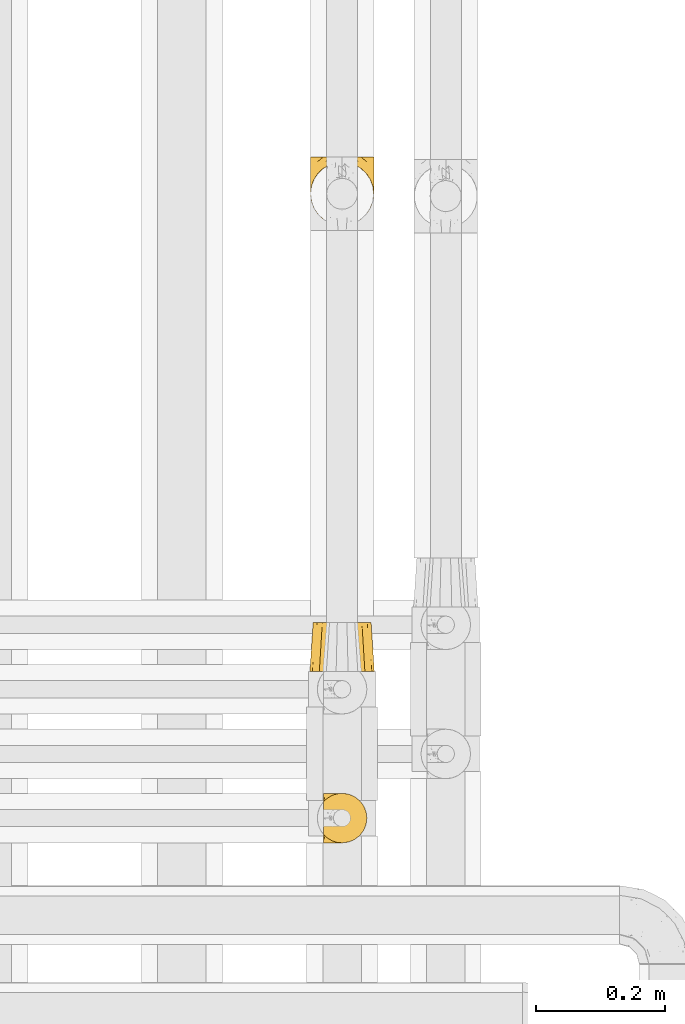
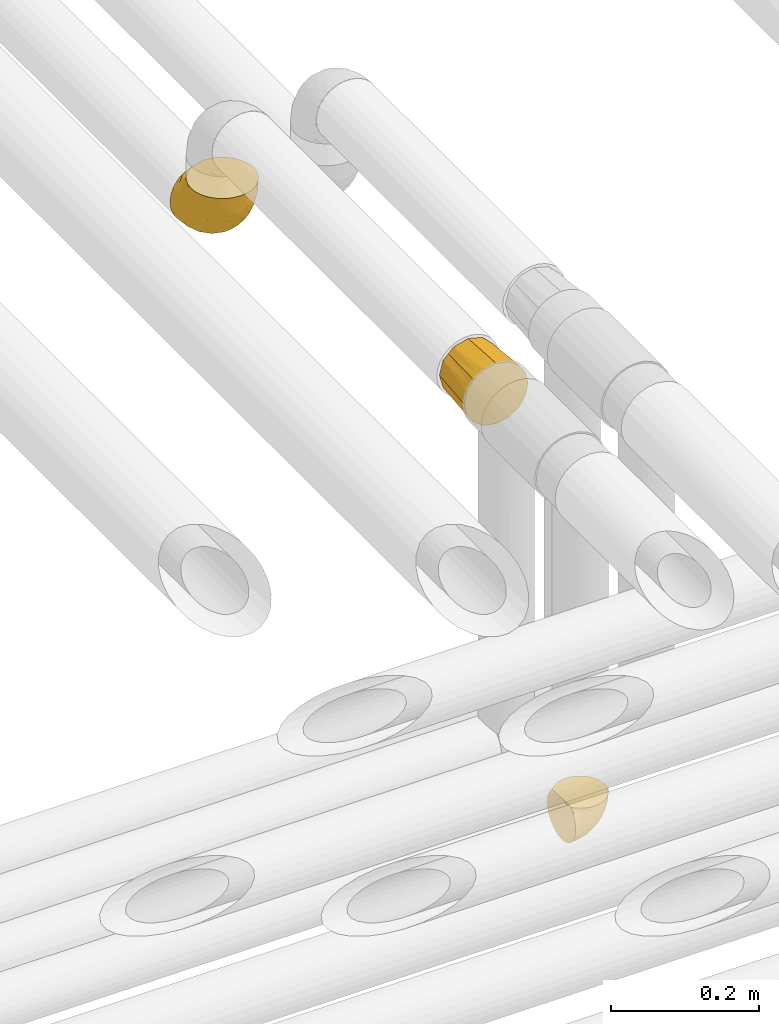
# One storey, part 344 of 827: 3 coverings.
"""IFC2X3 building model written with IfcOpenShell, lengths in millimetres."""

from ifc_helpers import new_model, entity, si_unit, converted_unit, derived_unit, direction, frame, origin, place, context, subcontext, project, spatial, faceted_brep, element, save


model = new_model("IFC2X3")

# Units and contexts
model_context = context("Model", 3, precision=0.01, world=origin(), true_north=direction((6.12303176911189e-17, 1.0)))
body_context = subcontext(model_context, "Body", "Model", "MODEL_VIEW")
ifc_project = project(units=[si_unit("LENGTHUNIT", "METRE", prefix="MILLI"), si_unit("AREAUNIT", "SQUARE_METRE"), si_unit("VOLUMEUNIT", "CUBIC_METRE"), converted_unit("PLANEANGLEUNIT", "DEGREE", entity("IfcRatioMeasure", 0.0174532925199433), si_unit("PLANEANGLEUNIT", "RADIAN"), dimensions=[0, 0, 0, 0, 0, 0, 0]), si_unit("MASSUNIT", "GRAM", prefix="KILO"), derived_unit("MASSDENSITYUNIT", [(si_unit("MASSUNIT", "GRAM", prefix="KILO"), 1), (si_unit("LENGTHUNIT", "METRE"), -3)]), derived_unit("MOMENTOFINERTIAUNIT", [(si_unit("LENGTHUNIT", "METRE"), 4)]), si_unit("TIMEUNIT", "SECOND"), si_unit("FREQUENCYUNIT", "HERTZ"), si_unit("THERMODYNAMICTEMPERATUREUNIT", "DEGREE_CELSIUS"), derived_unit("THERMALTRANSMITTANCEUNIT", [(si_unit("MASSUNIT", "GRAM", prefix="KILO"), 1), (si_unit("THERMODYNAMICTEMPERATUREUNIT", "KELVIN"), -1), (si_unit("TIMEUNIT", "SECOND"), -3)]), derived_unit("VOLUMETRICFLOWRATEUNIT", [(si_unit("LENGTHUNIT", "METRE"), 3), (si_unit("TIMEUNIT", "SECOND"), -1)]), derived_unit("MASSFLOWRATEUNIT", [(si_unit("MASSUNIT", "GRAM", prefix="KILO"), 1), (si_unit("TIMEUNIT", "SECOND"), -1)]), derived_unit("ROTATIONALFREQUENCYUNIT", [(si_unit("TIMEUNIT", "SECOND"), -1)]), si_unit("ELECTRICCURRENTUNIT", "AMPERE"), si_unit("ELECTRICVOLTAGEUNIT", "VOLT"), si_unit("POWERUNIT", "WATT"), si_unit("FORCEUNIT", "NEWTON", prefix="KILO"), si_unit("ILLUMINANCEUNIT", "LUX"), si_unit("LUMINOUSFLUXUNIT", "LUMEN"), si_unit("LUMINOUSINTENSITYUNIT", "CANDELA"), derived_unit("USERDEFINED", [(si_unit("MASSUNIT", "GRAM", prefix="KILO"), -1), (si_unit("LENGTHUNIT", "METRE"), -2), (si_unit("TIMEUNIT", "SECOND"), 3), (si_unit("LUMINOUSFLUXUNIT", "LUMEN"), 1)]), derived_unit("LINEARVELOCITYUNIT", [(si_unit("LENGTHUNIT", "METRE"), 1), (si_unit("TIMEUNIT", "SECOND"), -1)]), si_unit("PRESSUREUNIT", "PASCAL"), derived_unit("USERDEFINED", [(si_unit("LENGTHUNIT", "METRE"), -2), (si_unit("MASSUNIT", "GRAM", prefix="KILO"), 1), (si_unit("TIMEUNIT", "SECOND"), -2)]), derived_unit("LINEARFORCEUNIT", [(si_unit("MASSUNIT", "GRAM", prefix="KILO"), 1), (si_unit("LENGTHUNIT", "METRE"), 1), (si_unit("TIMEUNIT", "SECOND"), -2), (si_unit("LENGTHUNIT", "METRE"), -1)]), derived_unit("PLANARFORCEUNIT", [(si_unit("MASSUNIT", "GRAM", prefix="KILO"), 1), (si_unit("LENGTHUNIT", "METRE"), 1), (si_unit("TIMEUNIT", "SECOND"), -2), (si_unit("LENGTHUNIT", "METRE"), -2)])], contexts=[model_context])

# Site, building, storey
site_placement = place(None, origin())
site = spatial("IfcSite", under=ifc_project, at=site_placement, CompositionType="ELEMENT")
building_placement = place(site_placement, origin())
building = spatial("IfcBuilding", under=site, at=building_placement, CompositionType="ELEMENT")
storey_placement = place(building_placement, frame((0.0, 0.0, 28200.0)))
storey = spatial("IfcBuildingStorey", under=building, at=storey_placement, Name="08", CompositionType="ELEMENT", Elevation=28200.0)

# Coverings
covering_1_placement = place(storey_placement, frame((36438.02, 15249.95, 2959.95)))
element("IfcCovering", 1, at=covering_1_placement, inside=storey, Name=":ADSK_", ObjectType=":ADSK_", PredefinedType="INSULATION", context=body_context, shape_type="Brep", body=[
    faceted_brep([(1.6, 74.68, 23.36), (1.6, 70.1, 16.07), (1.6, 64.01, 9.98), (1.6, 56.72, 5.4), (1.6, 48.6, 2.56), (1.6, 40.05, 1.6), (1.6, 31.49, 2.56), (1.6, 23.36, 5.41), (1.6, 16.07, 9.99), (1.6, 9.98, 16.08), (1.6, 5.4, 23.37), (1.6, 2.56, 31.49), (1.6, 1.6, 40.05), (1.6, 2.46, 48.15), (1.6, 5.01, 55.88), (1.6, 9.13, 62.9), (1.6, 14.62, 68.89), (1.6, 16.82, 68.89), (1.6, 18.56, 68.89), (1.6, 20.52, 68.89), (1.6, 22.49, 68.89), (1.6, 24.46, 68.89), (1.6, 26.42, 68.89), (1.6, 28.39, 68.89), (1.6, 30.36, 68.89), (1.6, 32.55, 68.89), (1.6, 34.75, 68.89), (1.6, 36.94, 68.89), (1.6, 39.13, 68.89), (1.6, 41.33, 68.89), (1.6, 43.52, 68.89), (1.6, 45.72, 68.89), (1.6, 47.91, 68.89), (1.6, 50.11, 68.89), (1.6, 52.3, 68.89), (1.6, 54.49, 68.89), (1.6, 56.69, 68.89), (1.6, 58.88, 68.89), (1.6, 61.08, 68.89), (1.6, 63.27, 68.89), (1.6, 65.47, 68.89), (1.6, 70.97, 62.89), (1.6, 75.09, 55.86), (1.6, 77.64, 48.13), (1.6, 78.5, 40.05), (1.6, 77.53, 31.49), (1.85, 14.62, 69.15), (7.85, 9.12, 69.15), (14.87, 5.0, 69.15), (22.6, 2.46, 69.15), (30.7, 1.6, 69.15), (40.65, 2.91, 69.15), (49.92, 6.75, 69.15), (57.88, 12.86, 69.15), (63.99, 20.82, 69.15), (67.84, 30.09, 69.15), (69.15, 40.05, 69.15), (67.84, 50.0, 69.15), (63.99, 59.27, 69.15), (57.88, 67.23, 69.15), (49.92, 73.34, 69.15), (40.65, 77.19, 69.15), (30.7, 78.5, 69.15), (22.6, 77.63, 69.15), (14.87, 75.09, 69.15), (7.85, 70.97, 69.15), (1.85, 65.47, 69.15), (1.85, 63.27, 69.15), (1.85, 62.29, 69.15), (1.85, 60.7, 69.15), (1.85, 59.11, 69.15), (1.85, 57.52, 69.15), (1.85, 55.93, 69.15), (1.85, 54.34, 69.15), (1.85, 52.76, 69.15), (1.85, 51.17, 69.15), (1.85, 49.58, 69.15), (1.85, 47.99, 69.15), (1.85, 46.4, 69.15), (1.85, 44.81, 69.15), (1.85, 43.22, 69.15), (1.85, 41.63, 69.15), (1.85, 40.05, 69.15), (1.85, 38.46, 69.15), (1.85, 36.87, 69.15), (1.85, 35.28, 69.15), (1.85, 33.69, 69.15), (1.85, 32.1, 69.15), (1.85, 30.51, 69.15), (1.85, 28.92, 69.15), (1.85, 27.33, 69.15), (1.85, 25.37, 69.15), (1.85, 23.4, 69.15), (1.85, 21.21, 69.15), (1.85, 19.01, 69.15), (1.85, 16.82, 69.15), (1.77, 42.32, 68.96), (1.78, 44.02, 68.97), (1.77, 47.13, 68.97), (1.77, 48.74, 68.97), (1.76, 23.57, 68.95), (1.77, 25.13, 68.96), (1.79, 61.34, 68.98), (1.78, 22.02, 68.97), (1.78, 29.72, 68.97), (1.78, 56.73, 68.98), (1.78, 55.14, 68.97), (1.78, 37.66, 68.97), (1.74, 64.12, 68.94), (1.78, 28.13, 68.98), (1.78, 26.62, 68.98), (1.77, 31.46, 68.96), (1.78, 16.16, 68.97), (1.78, 39.16, 68.98), (1.78, 50.37, 68.98), (1.77, 17.69, 68.97), (1.77, 19.17, 68.96), (1.77, 62.78, 68.97), (1.78, 58.35, 68.97), (1.78, 45.53, 68.98), (1.77, 59.91, 68.96), (1.77, 65.47, 68.97), (1.72, 65.47, 68.94), (1.66, 65.47, 68.92), (1.77, 14.62, 68.97), (1.8, 14.62, 69.02), (1.82, 14.62, 69.08), (1.79, 20.59, 68.98), (1.78, 32.99, 68.97), (1.79, 34.48, 68.98), (1.78, 51.91, 68.97), (1.82, 65.47, 69.08), (1.8, 65.47, 69.02), (1.76, 53.48, 68.96), (1.66, 14.62, 68.92), (1.72, 14.62, 68.94), (1.78, 40.77, 68.97), (1.77, 35.97, 68.96), (9.41, 7.84, 67.02), (17.65, 3.53, 63.33), (7.41, 8.32, 64.61), (15.21, 2.19, 51.4), (7.41, 3.53, 53.1), (16.15, 1.6, 43.94), (28.75, 1.6, 61.87), (13.67, 4.57, 61.54), (12.79, 3.96, 57.95), (19.18, 2.28, 56.12), (29.16, 1.6, 63.4), (9.04, 7.69, 65.41), (5.74, 8.32, 63.04), (3.72, 7.84, 61.33), (8.87, 1.6, 41.99), (21.47, 1.6, 49.27), (26.8, 1.6, 54.6), (9.53, 4.34, 56.6), (7.34, 1.6, 41.58), (37.63, 29.63, 13.72), (17.92, 27.34, 5.82), (27.45, 40.05, 6.74), (37.01, 2.39, 58.82), (34.22, 2.43, 51.58), (45.87, 9.07, 42.09), (56.57, 16.64, 46.12), (52.31, 9.54, 55.56), (42.07, 4.52, 52.38), (44.74, 4.52, 61.54), (21.49, 7.49, 23.76), (11.02, 7.49, 20.5), (15.64, 12.85, 14.64), (26.02, 2.35, 41.77), (36.59, 22.66, 16.28), (65.49, 32.9, 49.4), (63.99, 25.33, 52.34), (15.2, 40.05, 4.3), (60.27, 16.64, 58.67), (45.25, 19.99, 25.26), (35.21, 16.37, 20.17), (22.52, 3.26, 34.7), (12.03, 3.75, 28.67), (13.32, 19.58, 8.62), (35.9, 7.5, 33.37), (33.87, 4.04, 41.35), (25.73, 13.94, 17.15), (26.34, 19.58, 12.68), (46.78, 28.21, 21.47), (59.54, 24.75, 41.11), (60.18, 31.42, 37.53), (53.93, 26.2, 30.64), (53.36, 33.36, 26.66), (49.36, 40.05, 21.38), (38.4, 40.05, 14.06), (66.44, 40.05, 55.54), (50.09, 16.14, 35.17), (41.08, 12.85, 29.04), (31.14, 10.47, 24.34), (28.19, 6.49, 29.33), (64.0, 40.05, 43.3), (56.68, 40.05, 32.34), (43.9, 75.57, 57.75), (65.46, 47.37, 49.41), (52.22, 52.91, 27.85), (37.61, 50.46, 13.7), (15.64, 67.23, 14.63), (13.31, 60.5, 8.61), (50.02, 70.55, 48.85), (59.28, 63.45, 54.13), (53.05, 62.61, 37.84), (21.48, 72.6, 23.75), (11.01, 72.6, 20.49), (12.03, 76.34, 28.66), (41.02, 59.34, 20.83), (35.39, 77.76, 55.15), (26.8, 78.5, 54.6), (28.75, 78.5, 61.87), (7.34, 78.5, 41.58), (65.81, 53.16, 57.58), (53.28, 70.55, 59.91), (59.8, 48.88, 36.94), (61.82, 54.76, 45.72), (17.91, 52.74, 5.82), (41.4, 71.93, 37.91), (40.48, 75.79, 50.18), (26.34, 60.5, 12.67), (31.68, 77.86, 49.29), (27.68, 77.64, 42.64), (16.15, 78.5, 43.94), (21.47, 78.5, 49.27), (28.05, 67.23, 19.45), (22.54, 76.82, 34.7), (8.87, 78.5, 41.99), (37.3, 77.8, 62.29), (41.07, 67.23, 29.01), (32.24, 73.2, 31.47), (47.4, 67.66, 37.18), (35.77, 75.99, 43.45), (17.65, 76.57, 63.33), (11.06, 73.21, 67.23), (8.55, 71.93, 66.07), (6.63, 71.07, 65.22), (12.77, 75.09, 61.99), (12.79, 76.13, 57.95), (7.41, 76.57, 53.09), (18.97, 77.69, 56.84), (3.72, 72.26, 61.33), (5.76, 71.77, 63.06), (15.21, 77.9, 51.41), (9.52, 75.75, 56.61)], [[[0, 1, 2, 3, 4, 5, 6, 7, 8, 9, 10, 11, 12, 13, 14, 15, 16, 17, 18, 19, 20, 21, 22, 23, 24, 25, 26, 27, 28, 29, 30, 31, 32, 33, 34, 35, 36, 37, 38, 39, 40, 41, 42, 43, 44, 45]], [[46, 47, 48, 49, 50, 51, 52, 53, 54, 55, 56, 57, 58, 59, 60, 61, 62, 63, 64, 65, 66, 67, 68, 69, 70, 71, 72, 73, 74, 75, 76, 77, 78, 79, 80, 81, 82, 83, 84, 85, 86, 87, 88, 89, 90, 91, 92, 93, 94, 95]], [[96, 97, 30]], [[98, 77, 99]], [[100, 101, 21]], [[69, 68, 102]], [[20, 19, 103]], [[24, 23, 104]], [[20, 103, 100]], [[72, 105, 106]], [[84, 83, 107]], [[89, 88, 104]], [[108, 67, 66]], [[109, 110, 90]], [[111, 25, 24]], [[112, 17, 16]], [[82, 113, 83]], [[109, 23, 22]], [[114, 76, 75]], [[105, 36, 106]], [[104, 111, 24]], [[18, 115, 116]], [[97, 96, 80]], [[67, 108, 117]], [[105, 71, 118]], [[31, 97, 119]], [[102, 120, 69]], [[108, 121, 122, 123, 40]], [[112, 95, 115]], [[17, 115, 18]], [[94, 116, 115]], [[117, 68, 67]], [[38, 117, 39]], [[112, 124, 125, 126, 46]], [[17, 112, 115]], [[70, 120, 118]], [[39, 117, 108]], [[120, 38, 37]], [[120, 37, 118]], [[120, 70, 69]], [[116, 94, 127]], [[128, 86, 129]], [[117, 38, 102]], [[74, 130, 75]], [[99, 33, 32]], [[115, 95, 94]], [[39, 108, 40]], [[108, 66, 131, 132, 121]], [[105, 72, 71]], [[118, 37, 36]], [[71, 70, 118]], [[35, 106, 36]], [[36, 105, 118]], [[35, 133, 106]], [[74, 73, 133]], [[106, 133, 73]], [[99, 114, 33]], [[133, 35, 34]], [[73, 72, 106]], [[95, 112, 46]], [[112, 16, 134, 135, 124]], [[130, 114, 75]], [[99, 76, 114]], [[114, 130, 33]], [[34, 33, 130]], [[78, 77, 98]], [[98, 119, 78]], [[130, 133, 34]], [[133, 130, 74]], [[79, 97, 80]], [[98, 99, 32]], [[98, 32, 31]], [[77, 76, 99]], [[97, 79, 119]], [[136, 96, 29]], [[30, 97, 31]], [[136, 29, 28]], [[81, 80, 96]], [[29, 96, 30]], [[31, 119, 98]], [[119, 79, 78]], [[96, 136, 81]], [[82, 81, 136]], [[113, 107, 83]], [[84, 107, 137]], [[107, 27, 137]], [[113, 28, 107]], [[27, 107, 28]], [[85, 84, 137]], [[137, 27, 26]], [[113, 136, 28]], [[136, 113, 82]], [[109, 89, 104]], [[86, 85, 129]], [[89, 109, 90]], [[111, 87, 128]], [[26, 129, 137]], [[88, 111, 104]], [[25, 111, 128]], [[22, 110, 109]], [[23, 109, 104]], [[110, 91, 90]], [[100, 92, 101]], [[110, 22, 101]], [[91, 110, 101]], [[116, 19, 18]], [[111, 88, 87]], [[127, 103, 19]], [[25, 128, 26]], [[86, 128, 87]], [[128, 129, 26]], [[137, 129, 85]], [[120, 102, 38]], [[117, 102, 68]], [[91, 101, 92]], [[21, 101, 22]], [[93, 92, 103]], [[100, 21, 20]], [[100, 103, 92]], [[127, 93, 103]], [[93, 127, 94]], [[116, 127, 19]], [[126, 138, 47]], [[48, 138, 139]], [[140, 125, 124]], [[141, 142, 143]], [[144, 49, 139]], [[145, 140, 146]], [[48, 139, 49]], [[139, 145, 147]], [[49, 144, 148, 50]], [[126, 125, 149]], [[14, 13, 142]], [[150, 146, 140]], [[149, 140, 145]], [[151, 150, 135]], [[151, 14, 142]], [[16, 15, 134]], [[13, 152, 142]], [[124, 150, 140]], [[141, 143, 153]], [[14, 151, 15]], [[15, 151, 134]], [[47, 46, 126]], [[139, 154, 144]], [[138, 48, 47]], [[125, 140, 149]], [[135, 134, 151]], [[146, 155, 141]], [[145, 146, 147]], [[149, 139, 138]], [[147, 153, 154]], [[147, 146, 141]], [[139, 147, 154]], [[139, 149, 145]], [[149, 138, 126]], [[147, 141, 153]], [[146, 150, 155]], [[151, 155, 150]], [[142, 141, 155]], [[13, 12, 156, 152]], [[152, 143, 142]], [[151, 142, 155]], [[150, 124, 135]], [[157, 158, 159]], [[160, 154, 161]], [[162, 163, 164]], [[165, 166, 160]], [[167, 168, 169]], [[153, 170, 161]], [[156, 12, 11]], [[158, 157, 171]], [[172, 55, 173]], [[158, 6, 174]], [[175, 54, 53]], [[52, 166, 164]], [[52, 164, 53]], [[54, 175, 173]], [[166, 52, 51]], [[176, 177, 171]], [[178, 143, 179]], [[156, 11, 179]], [[8, 7, 180]], [[169, 9, 8]], [[179, 143, 152, 156]], [[179, 11, 10]], [[168, 179, 10]], [[181, 162, 182]], [[179, 167, 178]], [[183, 184, 177]], [[183, 169, 184]], [[176, 171, 185]], [[172, 186, 187]], [[158, 7, 6]], [[159, 158, 174]], [[184, 180, 158]], [[54, 173, 55]], [[180, 169, 8]], [[188, 189, 187]], [[9, 168, 10]], [[186, 188, 187]], [[190, 157, 159, 191]], [[55, 172, 192]], [[176, 193, 194]], [[161, 170, 182]], [[162, 164, 165]], [[175, 164, 163]], [[51, 50, 148]], [[167, 195, 196]], [[178, 182, 170]], [[6, 5, 174]], [[158, 180, 7]], [[169, 180, 184]], [[169, 168, 9]], [[179, 168, 167]], [[182, 162, 165]], [[162, 194, 193]], [[161, 165, 160]], [[195, 181, 196]], [[192, 172, 197]], [[192, 56, 55]], [[189, 190, 198]], [[198, 197, 187]], [[172, 187, 197]], [[185, 189, 188]], [[198, 187, 189]], [[186, 172, 173]], [[173, 163, 186]], [[193, 186, 163]], [[176, 185, 188]], [[185, 157, 190]], [[188, 186, 193]], [[177, 176, 194]], [[188, 193, 176]], [[162, 193, 163]], [[195, 177, 194]], [[171, 177, 184]], [[181, 195, 194]], [[183, 167, 169]], [[162, 181, 194]], [[196, 182, 178]], [[158, 171, 184]], [[171, 157, 185]], [[177, 195, 183]], [[167, 183, 195]], [[182, 196, 181]], [[178, 170, 143]], [[178, 167, 196]], [[164, 175, 53]], [[173, 175, 163]], [[160, 51, 148]], [[164, 166, 165]], [[51, 160, 166]], [[160, 148, 144, 154]], [[153, 161, 154]], [[182, 165, 161]], [[190, 189, 185]], [[143, 170, 153]], [[60, 199, 61]], [[197, 200, 192]], [[201, 190, 202]], [[200, 57, 192]], [[203, 204, 2]], [[205, 206, 207]], [[208, 209, 210]], [[211, 207, 201]], [[212, 213, 214]], [[45, 215, 210]], [[216, 206, 58]], [[45, 44, 215]], [[59, 217, 60]], [[60, 217, 199]], [[0, 45, 210]], [[218, 201, 219]], [[202, 159, 220]], [[205, 221, 222]], [[223, 204, 203]], [[1, 203, 2]], [[57, 200, 216]], [[220, 3, 204]], [[220, 174, 4]], [[1, 0, 209]], [[212, 224, 213]], [[225, 226, 227]], [[228, 223, 203]], [[208, 210, 229]], [[210, 226, 229]], [[3, 220, 4]], [[58, 206, 59]], [[209, 203, 1]], [[202, 220, 223]], [[228, 203, 208]], [[202, 211, 201]], [[3, 2, 204]], [[202, 190, 191, 159]], [[210, 215, 230, 226]], [[199, 212, 231]], [[232, 233, 221]], [[233, 208, 229]], [[207, 206, 219]], [[217, 206, 205]], [[227, 224, 225]], [[233, 232, 228]], [[201, 207, 219]], [[234, 232, 221]], [[218, 219, 200]], [[202, 223, 211]], [[174, 220, 159]], [[174, 5, 4]], [[61, 231, 62]], [[220, 204, 223]], [[210, 209, 0]], [[203, 209, 208]], [[225, 233, 229]], [[224, 227, 213]], [[221, 233, 235]], [[57, 56, 192]], [[198, 218, 197]], [[200, 219, 216]], [[201, 198, 190]], [[197, 218, 200]], [[198, 201, 218]], [[206, 216, 219]], [[58, 57, 216]], [[231, 212, 214]], [[222, 212, 199]], [[228, 211, 223]], [[207, 211, 232]], [[62, 231, 214]], [[199, 231, 61]], [[233, 228, 208]], [[211, 228, 232]], [[222, 221, 235]], [[234, 205, 207]], [[206, 217, 59]], [[199, 217, 205]], [[205, 222, 199]], [[224, 222, 235]], [[222, 224, 212]], [[224, 235, 225]], [[233, 225, 235]], [[226, 225, 229]], [[205, 234, 221]], [[207, 232, 234]], [[63, 214, 236]], [[214, 213, 236]], [[214, 63, 62]], [[237, 236, 238]], [[238, 132, 131]], [[236, 237, 64]], [[239, 240, 241]], [[63, 236, 64]], [[131, 66, 65]], [[237, 131, 65]], [[242, 230, 43]], [[237, 65, 64]], [[239, 121, 132]], [[42, 242, 43]], [[241, 240, 243]], [[41, 123, 244]], [[43, 230, 215, 44]], [[244, 122, 245]], [[227, 246, 243]], [[241, 247, 245]], [[121, 239, 245]], [[41, 40, 123]], [[132, 238, 239]], [[244, 42, 41]], [[131, 237, 238]], [[240, 239, 238]], [[245, 239, 241]], [[247, 241, 246]], [[247, 244, 245]], [[238, 236, 240]], [[243, 236, 213]], [[236, 243, 240]], [[227, 226, 246]], [[243, 213, 227]], [[242, 246, 226]], [[243, 246, 241]], [[246, 242, 247]], [[244, 247, 242]], [[242, 226, 230]], [[42, 244, 242]], [[122, 244, 123]], [[122, 121, 245]]]),
])
covering_2_placement = place(storey_placement, frame((36417.97, 16208.19, 3349.15)))
element("IfcCovering", 2, at=covering_2_placement, inside=storey, Name=":ADSK_", ObjectType=":ADSK_", PredefinedType="INSULATION", context=body_context, shape_type="Brep", body=[
    faceted_brep([(1.6, 50.75, 107.75), (2.83, 39.8, 107.75), (6.47, 29.41, 107.75), (12.32, 20.09, 107.75), (20.11, 12.31, 107.75), (29.43, 6.46, 107.75), (39.81, 2.83, 107.75), (50.75, 1.6, 107.75), (61.69, 2.83, 107.75), (72.08, 6.47, 107.75), (81.4, 12.32, 107.75), (89.18, 20.11, 107.75), (95.03, 29.43, 107.75), (98.66, 39.81, 107.75), (99.9, 50.75, 107.75), (99.25, 56.45, 107.75), (98.66, 61.69, 107.75), (96.84, 66.88, 107.75), (95.02, 72.08, 107.75), (89.17, 81.4, 107.75), (81.38, 89.18, 107.75), (72.06, 95.03, 107.75), (61.68, 98.66, 107.75), (50.75, 99.9, 107.75), (39.8, 98.66, 107.75), (29.41, 95.02, 107.75), (20.09, 89.17, 107.75), (12.31, 81.38, 107.75), (6.46, 72.06, 107.75), (4.64, 66.87, 107.75), (2.83, 61.68, 107.75), (2.24, 56.45, 107.75), (1.92, 53.6, 107.75), (63.47, 107.75, 98.22), (75.32, 107.75, 93.31), (80.41, 107.75, 89.4), (85.5, 107.75, 85.5), (89.4, 107.75, 80.41), (93.31, 107.75, 75.32), (95.77, 107.75, 69.39), (98.22, 107.75, 63.47), (99.14, 107.75, 56.48), (99.52, 107.75, 53.61), (99.9, 107.75, 50.75), (98.22, 107.75, 38.02), (93.31, 107.75, 26.17), (85.5, 107.75, 15.99), (75.32, 107.75, 8.18), (63.47, 107.75, 3.27), (50.75, 107.75, 1.6), (38.02, 107.75, 3.27), (26.17, 107.75, 8.18), (15.99, 107.75, 15.99), (8.18, 107.75, 26.17), (3.27, 107.75, 38.02), (1.6, 107.75, 50.75), (2.35, 107.75, 56.48), (3.27, 107.75, 63.47), (5.73, 107.75, 69.39), (8.18, 107.75, 75.32), (12.09, 107.75, 80.41), (15.99, 107.75, 85.5), (21.08, 107.75, 89.4), (26.17, 107.75, 93.31), (38.02, 107.75, 98.22), (50.75, 107.75, 99.9), (42.18, 39.38, 27.53), (28.42, 49.75, 25.32), (37.78, 57.38, 16.29), (50.75, 74.94, 6.79), (42.85, 85.97, 4.51), (50.75, 95.66, 3.51), (24.75, 67.82, 17.47), (33.81, 83.09, 7.6), (22.57, 89.16, 12.27), (7.18, 37.01, 70.89), (2.73, 43.46, 87.17), (3.09, 51.79, 67.3), (6.92, 85.58, 31.65), (11.58, 62.84, 33.58), (5.17, 62.77, 47.23), (2.71, 88.17, 43.26), (1.6, 85.93, 55.08), (1.6, 91.42, 53.99), (1.6, 96.91, 52.9), (1.6, 99.62, 52.36), (1.6, 102.33, 51.82), (14.18, 82.57, 21.5), (5.88, 32.75, 89.94), (41.06, 13.79, 60.45), (36.25, 6.77, 83.0), (28.62, 16.46, 64.79), (1.6, 55.08, 85.93), (1.6, 58.17, 81.31), (1.6, 61.26, 76.69), (1.6, 64.35, 72.06), (1.6, 67.44, 67.44), (10.85, 24.18, 88.74), (38.35, 23.37, 45.98), (9.6, 49.76, 47.13), (26.24, 9.84, 89.4), (50.75, 3.51, 95.66), (19.31, 55.75, 28.5), (16.41, 42.34, 42.81), (24.56, 37.78, 38.28), (50.75, 21.87, 45.35), (50.75, 33.61, 33.61), (18.47, 17.1, 82.57), (1.6, 51.28, 105.04), (1.6, 51.82, 102.33), (1.6, 52.9, 96.91), (1.6, 53.99, 91.42), (14.36, 28.01, 65.92), (20.64, 28.99, 53.11), (2.32, 69.9, 54.37), (50.75, 6.79, 74.94), (1.6, 72.06, 64.35), (1.6, 76.69, 61.26), (1.6, 81.31, 58.17), (50.75, 45.35, 21.87), (33.88, 34.79, 34.79), (29.24, 25.72, 48.48), (50.75, 14.33, 60.15), (50.75, 60.15, 14.33), (2.8, 62.38, 99.07), (2.48, 100.57, 60.55), (2.7, 91.06, 64.18), (3.2, 97.66, 64.36), (32.98, 97.55, 103.17), (24.67, 93.65, 101.69), (2.95, 66.85, 87.75), (2.19, 61.93, 89.38), (17.92, 101.4, 88.34), (12.02, 100.07, 82.14), (25.73, 101.36, 94.51), (16.63, 95.94, 89.64), (25.6, 96.3, 98.41), (36.72, 101.98, 99.71), (10.66, 85.88, 89.37), (6.87, 78.88, 88.21), (11.12, 82.8, 95.2), (10.31, 102.58, 79.14), (12.84, 82.88, 101.22), (17.38, 88.57, 99.41), (9.74, 88.67, 84.72), (4.63, 69.08, 97.47), (50.75, 102.19, 102.19), (42.52, 100.06, 104.02), (3.12, 70.56, 82.66), (17.58, 91.07, 95.42), (3.97, 77.56, 78.67), (5.94, 96.59, 72.69), (2.73, 86.38, 66.46), (6.23, 91.79, 75.3), (3.45, 81.71, 72.74), (10.84, 94.11, 82.93), (7.98, 76.09, 99.27), (7.33, 76.91, 93.51), (2.39, 81.44, 67.35), (75.76, 101.37, 94.51), (90.65, 94.12, 82.94), (83.57, 101.41, 88.33), (84.85, 95.96, 89.64), (71.05, 96.22, 103.62), (98.54, 66.85, 87.74), (99.3, 61.94, 89.38), (99.9, 58.17, 81.31), (96.86, 69.1, 97.47), (84.1, 88.58, 99.41), (99.9, 96.91, 52.9), (99.9, 102.33, 51.82), (99.9, 105.04, 51.28), (88.63, 82.9, 101.21), (90.36, 82.82, 95.19), (98.29, 97.66, 64.36), (95.55, 96.59, 72.69), (89.47, 100.07, 82.13), (95.26, 91.79, 75.3), (91.18, 102.58, 79.14), (93.49, 76.13, 99.28), (94.15, 76.93, 93.51), (99.01, 100.57, 60.55), (98.76, 86.38, 66.46), (98.85, 90.86, 63.96), (99.9, 52.9, 96.91), (98.69, 62.39, 99.06), (64.78, 101.98, 99.7), (99.9, 91.42, 53.99), (99.9, 85.93, 55.08), (62.91, 99.49, 103.3), (99.9, 51.82, 102.33), (99.9, 52.36, 99.62), (99.9, 61.26, 76.69), (98.37, 70.56, 82.66), (83.9, 91.09, 95.42), (99.9, 64.35, 72.06), (97.51, 77.6, 78.68), (94.62, 78.89, 88.2), (98.04, 81.71, 72.75), (91.73, 88.69, 84.74), (99.9, 53.99, 91.42), (99.9, 55.08, 85.93), (75.87, 96.31, 98.41), (90.83, 85.9, 89.37), (99.1, 81.45, 67.35), (99.9, 76.69, 61.26), (99.9, 81.31, 58.17), (99.9, 72.06, 64.35), (99.9, 67.44, 67.44), (99.09, 69.6, 54.08), (58.64, 85.97, 4.51), (87.31, 82.57, 21.5), (89.93, 63.16, 33.43), (82.22, 55.81, 28.5), (76.74, 67.81, 17.47), (73.12, 49.73, 25.36), (95.54, 32.55, 90.18), (98.7, 43.23, 86.97), (98.79, 88.17, 43.26), (63.71, 57.38, 16.29), (67.68, 83.08, 7.6), (78.92, 89.16, 12.27), (94.57, 85.58, 31.65), (72.88, 16.46, 64.79), (65.25, 6.77, 83.0), (60.44, 13.8, 60.44), (76.94, 37.71, 38.35), (67.61, 34.8, 34.8), (94.38, 36.83, 71.54), (59.31, 39.38, 27.53), (83.03, 17.12, 82.57), (90.66, 24.19, 88.74), (80.8, 28.89, 53.19), (72.22, 25.69, 48.49), (98.39, 51.77, 67.28), (92.31, 45.66, 52.32), (63.11, 23.39, 45.94), (75.27, 9.85, 89.4), (87.15, 28.11, 65.75), (96.03, 62.27, 46.73), (85.1, 42.35, 42.82)], [[[0, 1, 2, 3, 4, 5, 6, 7, 8, 9, 10, 11, 12, 13, 14, 15, 16, 17, 18, 19, 20, 21, 22, 23, 24, 25, 26, 27, 28, 29, 30, 31, 32]], [[33, 34, 35, 36, 37, 38, 39, 40, 41, 42, 43, 44, 45, 46, 47, 48, 49, 50, 51, 52, 53, 54, 55, 56, 57, 58, 59, 60, 61, 62, 63, 64, 65]], [[66, 67, 68]], [[69, 70, 71]], [[68, 72, 73]], [[73, 72, 74]], [[75, 76, 77]], [[78, 79, 80]], [[51, 50, 73]], [[81, 82, 83, 84, 85, 86, 55]], [[52, 87, 53]], [[74, 52, 51]], [[2, 1, 88]], [[89, 90, 91]], [[77, 92, 93, 94, 95, 96]], [[55, 54, 81]], [[78, 53, 87]], [[5, 90, 6]], [[88, 76, 75]], [[97, 3, 2]], [[89, 91, 98]], [[99, 80, 79]], [[90, 5, 100]], [[74, 87, 52]], [[100, 5, 4]], [[90, 101, 6]], [[79, 102, 103]], [[102, 67, 104]], [[105, 98, 106]], [[107, 4, 3]], [[76, 0, 108, 109, 110, 111, 92]], [[107, 112, 113]], [[114, 77, 96]], [[89, 115, 90]], [[114, 96, 116, 117, 118, 82]], [[75, 97, 88]], [[119, 66, 68]], [[50, 71, 70]], [[100, 91, 90]], [[99, 77, 80]], [[102, 104, 103]], [[97, 107, 3]], [[80, 81, 78]], [[107, 97, 112]], [[68, 73, 70]], [[66, 98, 120]], [[78, 81, 54]], [[114, 81, 80]], [[53, 78, 54]], [[78, 87, 79]], [[102, 87, 72]], [[79, 103, 99]], [[4, 107, 100]], [[91, 100, 107]], [[88, 97, 2]], [[112, 97, 75]], [[99, 112, 75]], [[103, 104, 113]], [[91, 121, 98]], [[89, 105, 122, 115]], [[101, 90, 115]], [[101, 7, 6]], [[88, 1, 76]], [[0, 76, 1]], [[92, 77, 76]], [[73, 74, 51]], [[87, 74, 72]], [[81, 114, 82]], [[77, 114, 80]], [[87, 102, 79]], [[67, 102, 72]], [[68, 67, 72]], [[67, 120, 104]], [[120, 121, 104]], [[104, 121, 113]], [[121, 120, 98]], [[91, 107, 113]], [[91, 113, 121]], [[103, 113, 112]], [[106, 98, 66]], [[105, 89, 98]], [[106, 66, 119]], [[67, 66, 120]], [[68, 69, 123, 119]], [[50, 49, 71]], [[50, 70, 73]], [[112, 99, 103]], [[77, 99, 75]], [[69, 68, 70]], [[29, 124, 110]], [[84, 83, 125]], [[126, 82, 118]], [[59, 58, 127]], [[25, 128, 129]], [[130, 93, 131]], [[132, 62, 133]], [[134, 135, 136]], [[137, 65, 64]], [[64, 134, 137]], [[138, 139, 140]], [[111, 110, 124, 92]], [[134, 136, 137]], [[134, 64, 63]], [[141, 61, 60]], [[125, 58, 57]], [[142, 143, 140]], [[142, 26, 143]], [[127, 83, 82]], [[28, 124, 29]], [[108, 0, 32, 31, 30, 110, 109]], [[30, 29, 110]], [[135, 144, 138]], [[28, 145, 124]], [[57, 56, 55, 86, 85, 84]], [[146, 147, 23]], [[24, 23, 147]], [[25, 143, 26]], [[95, 94, 148]], [[24, 128, 25]], [[149, 138, 143]], [[124, 145, 131]], [[127, 58, 125]], [[150, 148, 139]], [[127, 126, 151]], [[151, 59, 127]], [[152, 151, 126]], [[153, 154, 155]], [[153, 133, 141]], [[145, 28, 27]], [[142, 156, 27]], [[157, 148, 130]], [[61, 133, 62]], [[134, 132, 135]], [[147, 128, 24]], [[65, 137, 146]], [[146, 137, 147]], [[128, 137, 136]], [[137, 128, 147]], [[128, 136, 129]], [[149, 129, 136]], [[25, 129, 143]], [[158, 152, 117]], [[152, 118, 117]], [[153, 151, 152]], [[158, 116, 154]], [[144, 150, 138]], [[153, 152, 158]], [[133, 153, 155]], [[133, 155, 132]], [[60, 151, 141]], [[135, 132, 155]], [[134, 63, 132]], [[144, 135, 155]], [[135, 138, 149]], [[155, 154, 144]], [[150, 154, 96]], [[154, 150, 144]], [[148, 94, 130]], [[82, 126, 127]], [[118, 152, 126]], [[150, 96, 95]], [[139, 148, 157]], [[150, 95, 148]], [[93, 92, 131]], [[130, 145, 156]], [[130, 94, 93]], [[84, 125, 57]], [[127, 125, 83]], [[140, 139, 157]], [[150, 139, 138]], [[140, 157, 142]], [[138, 140, 143]], [[156, 142, 157]], [[27, 26, 142]], [[130, 156, 157]], [[145, 27, 156]], [[132, 63, 62]], [[124, 131, 92]], [[130, 131, 145]], [[129, 149, 143]], [[135, 149, 136]], [[141, 133, 61]], [[60, 59, 151]], [[141, 151, 153]], [[116, 96, 154]], [[153, 158, 154]], [[158, 117, 116]], [[34, 33, 159]], [[160, 161, 162]], [[22, 21, 163]], [[164, 165, 166]], [[19, 18, 167]], [[168, 21, 20]], [[42, 41, 40, 169, 170, 171, 43]], [[172, 173, 168]], [[174, 38, 175]], [[176, 177, 178]], [[179, 164, 180]], [[40, 181, 169]], [[182, 183, 175]], [[17, 184, 185]], [[65, 146, 186]], [[187, 174, 188]], [[23, 22, 189]], [[174, 39, 38]], [[15, 14, 190, 191, 184, 16]], [[181, 40, 39]], [[192, 193, 164]], [[194, 163, 168]], [[33, 186, 159]], [[180, 173, 172]], [[195, 196, 193]], [[18, 185, 167]], [[173, 180, 197]], [[198, 199, 196]], [[200, 201, 185, 184]], [[184, 17, 16]], [[18, 17, 185]], [[202, 159, 186]], [[194, 168, 203]], [[189, 163, 202]], [[204, 205, 182]], [[187, 181, 174]], [[160, 177, 176]], [[206, 183, 182]], [[206, 182, 205]], [[201, 165, 185]], [[165, 164, 167]], [[172, 179, 180]], [[202, 194, 162]], [[176, 161, 160]], [[65, 186, 33]], [[163, 189, 22]], [[175, 177, 182]], [[174, 183, 188]], [[177, 198, 204]], [[199, 160, 162]], [[198, 207, 204]], [[175, 38, 37]], [[198, 177, 160]], [[178, 177, 175]], [[176, 35, 161]], [[34, 159, 161]], [[162, 161, 159]], [[202, 162, 159]], [[199, 162, 203]], [[196, 199, 203]], [[198, 160, 199]], [[193, 197, 180]], [[208, 198, 196]], [[188, 183, 206]], [[175, 183, 174]], [[193, 192, 195]], [[195, 208, 196]], [[197, 196, 203]], [[180, 164, 193]], [[168, 163, 21]], [[166, 165, 201]], [[166, 192, 164]], [[189, 202, 186]], [[186, 146, 189]], [[23, 189, 146]], [[174, 181, 39]], [[169, 181, 187]], [[196, 197, 193]], [[173, 203, 168]], [[203, 173, 197]], [[172, 168, 20]], [[20, 19, 172]], [[179, 172, 19]], [[19, 167, 179]], [[164, 179, 167]], [[35, 176, 36]], [[35, 34, 161]], [[185, 165, 167]], [[162, 194, 203]], [[163, 194, 202]], [[176, 178, 36]], [[37, 36, 178]], [[175, 37, 178]], [[177, 204, 182]], [[207, 198, 208]], [[207, 205, 204]], [[209, 188, 206, 205, 207, 208]], [[48, 210, 71]], [[211, 212, 213]], [[214, 213, 215]], [[216, 217, 13]], [[218, 43, 171, 170, 169, 187, 188]], [[219, 220, 214]], [[47, 46, 221]], [[210, 48, 220]], [[211, 222, 212]], [[222, 45, 44]], [[221, 220, 47]], [[47, 220, 48]], [[221, 211, 214]], [[223, 224, 225]], [[211, 46, 45]], [[226, 227, 215]], [[43, 218, 44]], [[217, 216, 228]], [[219, 215, 229]], [[14, 13, 217]], [[224, 9, 8]], [[10, 230, 11]], [[11, 231, 12]], [[232, 223, 233]], [[234, 208, 195, 192, 166, 201]], [[235, 234, 228]], [[222, 44, 218]], [[106, 229, 236]], [[224, 237, 9]], [[231, 238, 228]], [[9, 237, 10]], [[115, 224, 101]], [[239, 234, 235]], [[231, 11, 230]], [[223, 230, 237]], [[224, 8, 101]], [[223, 236, 233]], [[225, 115, 122, 105]], [[216, 12, 231]], [[209, 234, 239]], [[210, 219, 69]], [[219, 214, 215]], [[229, 119, 219]], [[209, 218, 188]], [[239, 212, 222]], [[239, 222, 218]], [[45, 222, 211]], [[235, 212, 239]], [[213, 212, 240]], [[223, 237, 224]], [[230, 10, 237]], [[238, 231, 230]], [[216, 231, 228]], [[232, 230, 223]], [[235, 238, 240]], [[115, 225, 224]], [[233, 236, 227]], [[8, 7, 101]], [[234, 209, 208]], [[218, 209, 239]], [[217, 228, 234]], [[13, 12, 216]], [[234, 201, 217]], [[217, 201, 200, 184, 191, 190, 14]], [[211, 221, 46]], [[220, 221, 214]], [[71, 210, 69]], [[71, 49, 48]], [[219, 210, 220]], [[226, 215, 213]], [[211, 213, 214]], [[226, 213, 240]], [[215, 227, 229]], [[232, 240, 238]], [[233, 227, 226]], [[232, 233, 226]], [[236, 223, 225]], [[240, 232, 226]], [[232, 238, 230]], [[225, 105, 236]], [[236, 105, 106]], [[236, 229, 227]], [[123, 69, 219, 119]], [[106, 119, 229]], [[238, 235, 228]], [[212, 235, 240]]]),
])
covering_3_placement = place(storey_placement, frame((36417.12, 15517.5, 3498.4)))
element("IfcCovering", 3, at=covering_3_placement, inside=storey, Name=":ADSK_", ObjectType=":ADSK_", PredefinedType="INSULATION", context=body_context, shape_type="Brep", body=[
    faceted_brep([(96.6, 76.0, 51.6), (93.58, 76.0, 40.35), (90.57, 76.0, 29.1), (82.33, 76.0, 20.86), (74.1, 76.0, 12.62), (62.85, 76.0, 9.61), (51.6, 76.0, 6.6), (40.35, 76.0, 9.61), (29.1, 76.0, 12.62), (20.86, 76.0, 20.86), (12.62, 76.0, 29.1), (9.61, 76.0, 40.35), (6.6, 76.0, 51.6), (9.61, 76.0, 62.85), (12.62, 76.0, 74.1), (20.86, 76.0, 82.33), (29.1, 76.0, 90.57), (40.35, 76.0, 93.58), (51.6, 76.0, 96.6), (62.85, 76.0, 93.58), (74.1, 76.0, 90.57), (82.33, 76.0, 82.33), (90.57, 76.0, 74.1), (93.58, 76.0, 62.85), (5.4, 0.0, 70.73), (3.5, 0.0, 61.16), (1.6, 0.0, 51.6), (3.5, 0.0, 42.03), (5.4, 0.0, 32.46), (10.82, 0.0, 24.35), (16.24, 0.0, 16.24), (24.35, 0.0, 10.82), (32.46, 0.0, 5.4), (42.03, 0.0, 3.5), (51.6, 0.0, 1.6), (61.16, 0.0, 3.5), (70.73, 0.0, 5.4), (78.84, 0.0, 10.82), (86.95, 0.0, 16.24), (92.37, 0.0, 24.35), (97.79, 0.0, 32.46), (99.69, 0.0, 42.03), (101.6, 0.0, 51.6), (99.69, 0.0, 61.16), (97.79, 0.0, 70.73), (92.37, 0.0, 78.84), (86.95, 0.0, 86.95), (78.84, 0.0, 92.37), (70.73, 0.0, 97.79), (61.16, 0.0, 99.69), (51.6, 0.0, 101.6), (42.03, 0.0, 99.69), (32.46, 0.0, 97.79), (24.35, 0.0, 92.37), (16.24, 0.0, 86.95), (10.82, 0.0, 78.84)], [[[0, 1, 2, 3, 4, 5, 6, 7, 8, 9, 10, 11, 12, 13, 14, 15, 16, 17, 18, 19, 20, 21, 22, 23]], [[24, 25, 26, 27, 28, 29, 30, 31, 32, 33, 34, 35, 36, 37, 38, 39, 40, 41, 42, 43, 44, 45, 46, 47, 48, 49, 50, 51, 52, 53, 54, 55]], [[35, 34, 6]], [[37, 36, 4]], [[37, 4, 3]], [[2, 39, 3]], [[37, 3, 38]], [[41, 0, 42]], [[6, 5, 35]], [[39, 38, 3]], [[0, 41, 1]], [[5, 4, 36]], [[5, 36, 35]], [[40, 2, 1]], [[41, 40, 1]], [[2, 40, 39]], [[27, 26, 12]], [[29, 28, 10]], [[29, 10, 9]], [[8, 31, 9]], [[29, 9, 30]], [[33, 6, 34]], [[12, 11, 27]], [[31, 30, 9]], [[6, 33, 7]], [[11, 10, 28]], [[11, 28, 27]], [[32, 8, 7]], [[33, 32, 7]], [[8, 32, 31]], [[51, 50, 18]], [[53, 52, 16]], [[53, 16, 15]], [[14, 55, 15]], [[53, 15, 54]], [[25, 12, 26]], [[18, 17, 51]], [[55, 54, 15]], [[12, 25, 13]], [[17, 16, 52]], [[17, 52, 51]], [[24, 14, 13]], [[25, 24, 13]], [[14, 24, 55]], [[43, 42, 0]], [[45, 44, 22]], [[45, 22, 21]], [[20, 47, 21]], [[45, 21, 46]], [[49, 18, 50]], [[0, 23, 43]], [[47, 46, 21]], [[18, 49, 19]], [[23, 22, 44]], [[23, 44, 43]], [[48, 20, 19]], [[49, 48, 19]], [[20, 48, 47]]]),
])

save(model, "model.ifc")
